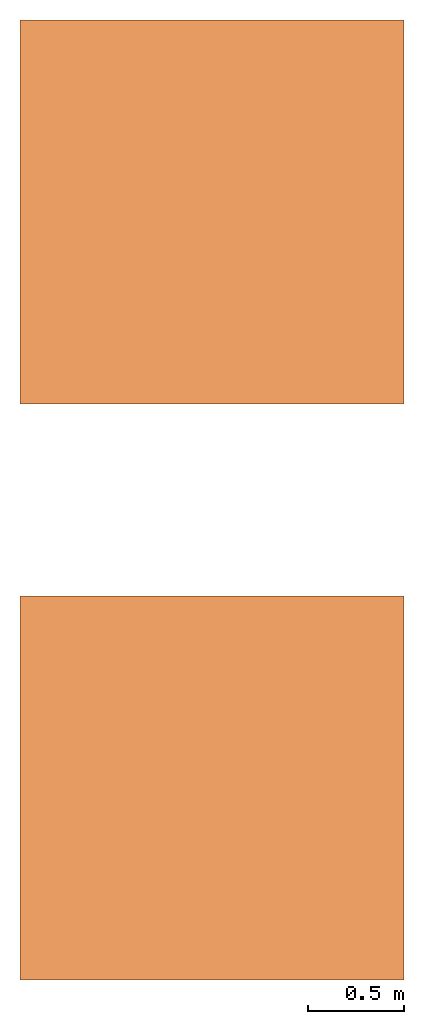
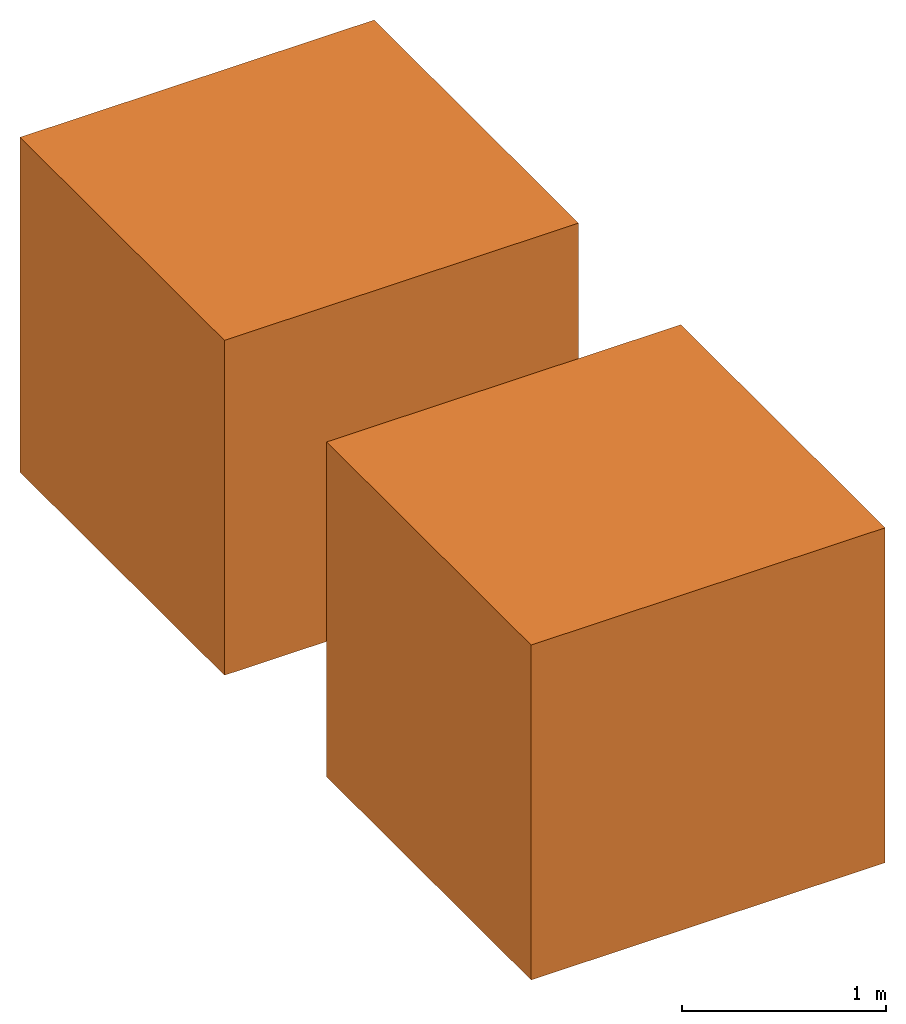
# One storey: 2 proxies.
"""IFC4 building model written with IfcOpenShell, lengths in metres."""

from ifc_helpers import new_model, si_unit, frame, origin_with_axes, place, context, subcontext, project, spatial, faceted_brep, source, transform, mapped, material, element, save


model = new_model("IFC4")

# Units and contexts
model_context = context("Model", 3, precision=1e-05, world=origin_with_axes())
plan_context = context("Plan", 2, precision=1e-05, world=origin_with_axes())
body_context = subcontext(model_context, "Body", "Model", "MODEL_VIEW")
ifc_project = project(units=[si_unit("LENGTHUNIT", "METRE"), si_unit("AREAUNIT", "SQUARE_METRE"), si_unit("VOLUMEUNIT", "CUBIC_METRE")], contexts=[model_context, plan_context])

# Site, building, storey
site_placement = place(None, origin_with_axes())
site = spatial("IfcSite", under=ifc_project, at=site_placement)
building_placement = place(site_placement, origin_with_axes())
building = spatial("IfcBuilding", under=site, at=building_placement, Name="Building")
storey_placement = place(building_placement, origin_with_axes())
storey = spatial("IfcBuildingStorey", under=building, at=storey_placement, Name="Ground Floor")

# Proxies
ifc_material = material(Name="Material")
shared_shape = source(origin_with_axes(), body_context, "Body", "Brep", [
    faceted_brep([(1.0, 1.0, 1.0), (-1.0, 1.0, 1.0), (-1.0, -1.0, 1.0), (1.0, -1.0, 1.0), (1.0, -1.0, -1.0), (-1.0, -1.0, -1.0), (-1.0, 1.0, -1.0), (1.0, 1.0, -1.0)], [[[0, 1, 2, 3]], [[4, 3, 2, 5]], [[5, 2, 1, 6]], [[6, 7, 4, 5]], [[7, 0, 3, 4]], [[6, 1, 0, 7]]]),
])
for number, where, z_axis, x_axis, name in (
    (1, (0.0, 0.0, 0.0), (0.0, 0.0, 1.0), (1.0, 0.0, 0.0), "Cube"),
    (2, (0.0, 3.0, -5.96046447753906e-08), (0.0, 0.0, 1.0), (1.0, 0.0, 0.0), "Cube.001"),
):
    element("IfcBuildingElementProxy", number, at=place(storey_placement, frame(where, z_axis=z_axis, x_axis=x_axis)), inside=storey, material=ifc_material, Name=name, PredefinedType="NOTDEFINED", context=body_context, shape_type="Brep", body=[
        mapped(shared_shape, transform((0.0, 0.0, 0.0), x_axis=(1.0, 0.0, 0.0), y_axis=(0.0, 1.0, 0.0), z_axis=(0.0, 0.0, 1.0), scale=1.0)),
    ])

save(model, "model.ifc")
